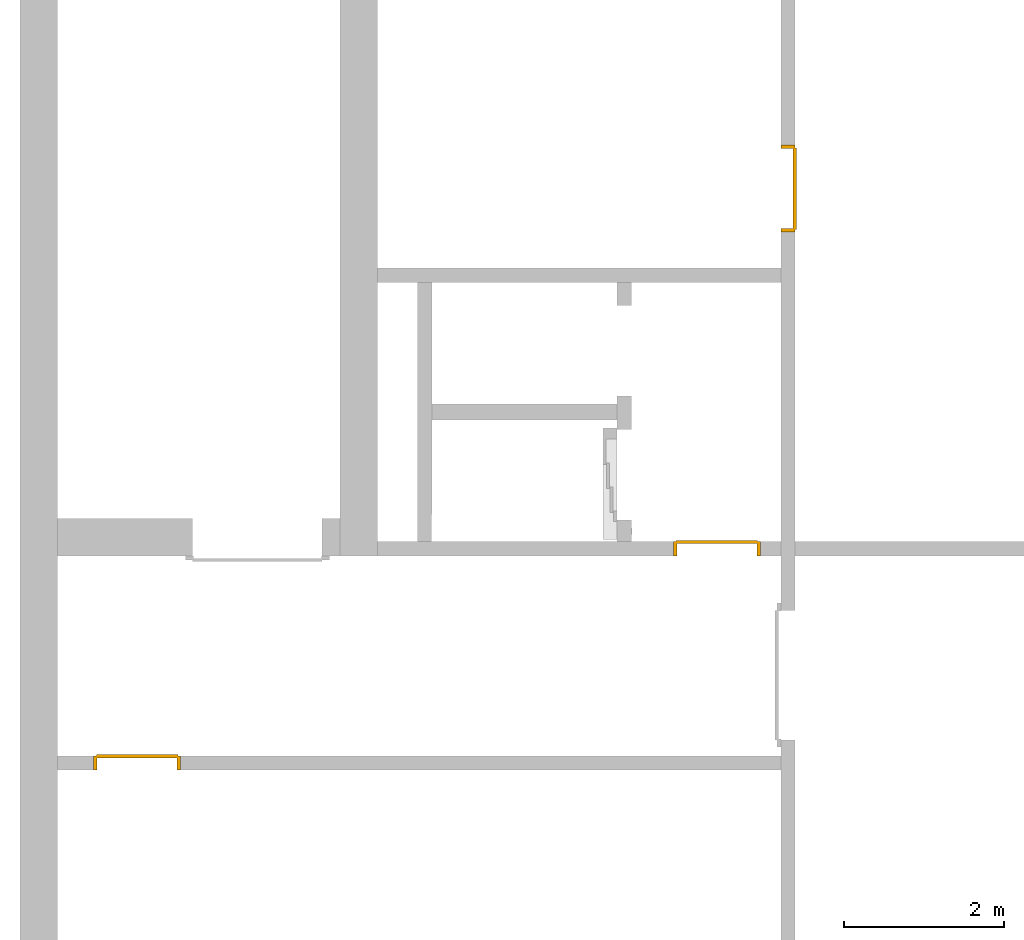
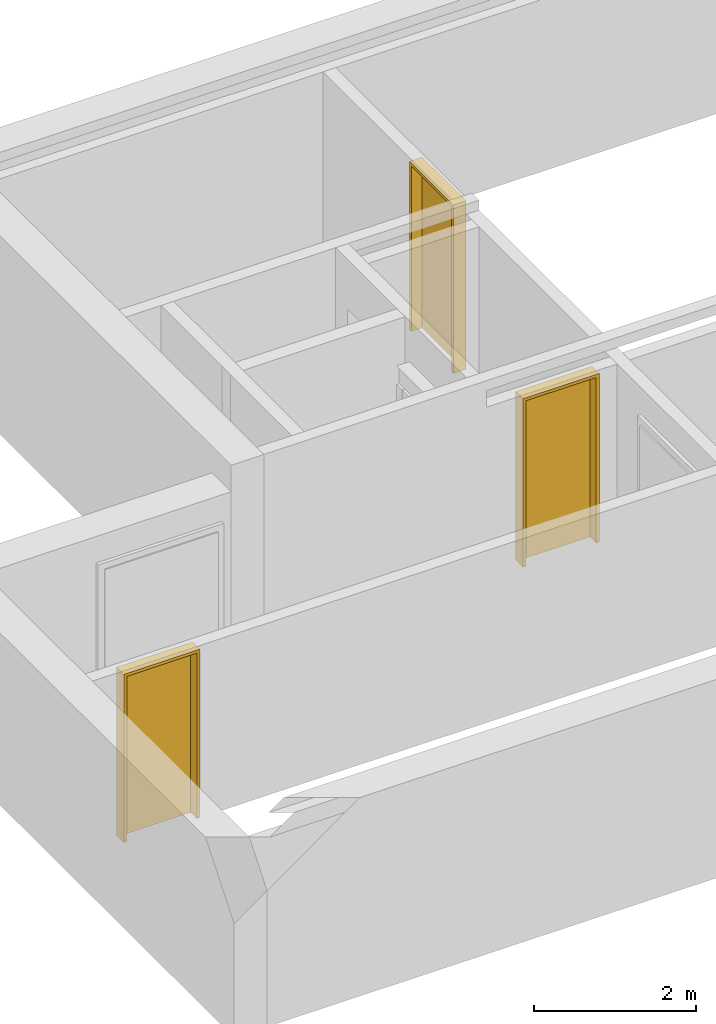
# One storey, part 3 of 3: 3 doors.
"""IFC4 building model written with IfcOpenShell, lengths in metres."""

from ifc_helpers import new_model, entity, si_unit, converted_unit, derived_unit, direction, frame, origin_with_axes, place, context, subcontext, project, spatial, polygons, type_object, element, save


model = new_model("IFC4")

# Units and contexts
model_context = context("Model", 3, precision=1e-05, world=origin_with_axes(), true_north=direction((0.0, 1.0)))
body_context = subcontext(model_context, "Body", "Model", "MODEL_VIEW")
ifc_project = project(units=[si_unit("LENGTHUNIT", "METRE"), si_unit("AREAUNIT", "SQUARE_METRE"), si_unit("VOLUMEUNIT", "CUBIC_METRE"), converted_unit("PLANEANGLEUNIT", "DEGREE", entity("IfcPlaneAngleMeasure", 0.0174532925199433), si_unit("PLANEANGLEUNIT", "RADIAN"), dimensions=[0, 0, 0, 0, 0, 0, 0]), converted_unit("TIMEUNIT", "Year", entity("IfcTimeMeasure", 31557600.0), si_unit("TIMEUNIT", "SECOND"), dimensions=[0, 0, 1, 0, 0, 0, 0]), si_unit("MASSUNIT", "GRAM", prefix="KILO"), si_unit("THERMODYNAMICTEMPERATUREUNIT", "DEGREE_CELSIUS"), si_unit("LUMINOUSINTENSITYUNIT", "LUMEN"), si_unit("ENERGYUNIT", "JOULE", prefix="MEGA"), derived_unit("THERMALCONDUCTANCEUNIT", [(si_unit("POWERUNIT", "WATT"), 1), (si_unit("LENGTHUNIT", "METRE"), -1), (si_unit("THERMODYNAMICTEMPERATUREUNIT", "KELVIN"), -1)]), derived_unit("SPECIFICHEATCAPACITYUNIT", [(si_unit("ENERGYUNIT", "JOULE"), 1), (si_unit("MASSUNIT", "GRAM", prefix="KILO"), -1), (si_unit("THERMODYNAMICTEMPERATUREUNIT", "KELVIN"), -1)]), derived_unit("MASSDENSITYUNIT", [(si_unit("MASSUNIT", "GRAM", prefix="KILO"), 1), (si_unit("VOLUMEUNIT", "CUBIC_METRE"), -1)])], contexts=[model_context])

# Site, building, storey
site_placement = place(None, origin_with_axes())
site = spatial("IfcSite", under=ifc_project, at=site_placement, CompositionType="ELEMENT")
building_placement = place(None, origin_with_axes())
building = spatial("IfcBuilding", under=site, at=building_placement, CompositionType="ELEMENT")
storey_placement = place(None, frame((0.0, 0.0, -3.0), z_axis=(0.0, 0.0, 1.0), x_axis=(1.0, 0.0, 0.0)))
storey = spatial("IfcBuildingStorey", under=building, at=storey_placement, Name="UG", CompositionType="ELEMENT", Elevation=-3.0)

# Doors
door_type_1 = type_object("IfcDoorType", Name="27", OperationType="SINGLE_SWING_LEFT", PredefinedType="DOOR")
door_1_placement = place(None, frame((33.505, 12.1499999454676, -3.0), z_axis=(0.0, 0.0, 1.0), x_axis=(0.0, -1.0, 0.0)))
element("IfcDoor", 1, at=door_1_placement, inside=storey, type_object=door_type_1, OverallHeight=2.545, OverallWidth=1.09, context=body_context, shape_type="Tessellation", body=[
    polygons([(-0.0449999999999999, 0.0, 0.0), (-0.0449999999999999, 0.0, 2.545), (-0.0449999999999999, 0.155000000000001, 2.545), (-0.0449999999999999, 0.155000000000001, 0.0), (0.0, 0.0, 0.0), (0.0, 0.0, 2.5), (0.444900000000001, 0.0, 2.5), (0.4999, 0.0, 2.5), (1.0, 0.0, 2.5), (1.0, 0.0, 0.0), (1.045, 0.0, 0.0), (1.045, 0.0, 2.545), (1.045, 0.155000000000001, 2.545), (1.045, 0.155000000000001, 0.0), (1.0, 0.155000000000001, 0.0), (1.0, 0.155000000000001, 2.5), (0.4999, 0.155000000000001, 2.5), (0.444900000000001, 0.155000000000001, 2.5), (0.0, 0.155000000000001, 2.5), (0.0, 0.155000000000001, 0.0)], [[[1, 2, 3, 4]], [[1, 5, 6, 7, 8, 9, 10, 11, 12, 2]], [[2, 12, 13, 3]], [[4, 3, 13, 14, 15, 16, 17, 18, 19, 20]], [[5, 1, 4, 20]], [[6, 5, 20, 19]], [[7, 6, 19, 18]], [[8, 7, 18, 17]], [[9, 8, 17, 16]], [[10, 9, 16, 15]], [[11, 10, 15, 14]], [[12, 11, 14, 13]]], closed=True),
    polygons([(-0.0449999999999999, 0.155000000000001, 0.0), (-0.0449999999999999, 0.155000000000001, 2.545), (-0.0449999999999999, 0.18, 2.545), (-0.0449999999999999, 0.18, 0.0), (-0.00999999999999979, 0.155000000000001, 0.0), (-0.00999999999999979, 0.155000000000001, 2.51), (0.4549, 0.155000000000001, 2.51), (0.4899, 0.155000000000001, 2.51), (1.01, 0.155000000000001, 2.51), (1.01, 0.155000000000001, 0.0), (1.045, 0.155000000000001, 0.0), (1.045, 0.155000000000001, 2.545), (1.045, 0.18, 2.545), (1.045, 0.18, 0.0), (1.01, 0.18, 0.0), (1.01, 0.18, 2.51), (0.4899, 0.18, 2.51), (0.4549, 0.18, 2.51), (-0.00999999999999979, 0.18, 2.51), (-0.00999999999999979, 0.18, 0.0)], [[[1, 2, 3, 4]], [[1, 5, 6, 7, 8, 9, 10, 11, 12, 2]], [[2, 12, 13, 3]], [[4, 3, 13, 14, 15, 16, 17, 18, 19, 20]], [[5, 1, 4, 20]], [[6, 5, 20, 19]], [[7, 6, 19, 18]], [[8, 7, 18, 17]], [[9, 8, 17, 16]], [[10, 9, 16, 15]], [[11, 10, 15, 14]], [[12, 11, 14, 13]]], closed=True),
    polygons([(-0.00999999999999979, 0.195, 0.0), (-0.00999999999999979, 0.195, 2.51), (1.01, 0.195, 2.51), (1.01, 0.195, 0.0), (-0.00999999999999979, 0.155000000000001, 0.0), (-0.00999999999999979, 0.155000000000001, 2.51), (1.01, 0.155000000000001, 2.51), (1.01, 0.155000000000001, 0.0)], [[[1, 2, 3, 4]], [[1, 5, 6, 2]], [[2, 6, 7, 3]], [[3, 7, 8, 4]], [[4, 8, 5, 1]], [[8, 7, 6, 5]]], closed=True),
])
door_2_placement = place(None, frame((24.953, 4.55499994546755, -3.0), z_axis=(0.0, 0.0, 1.0), x_axis=(1.0, 0.0, 0.0)))
element("IfcDoor", 2, at=door_2_placement, inside=storey, type_object=door_type_1, OverallHeight=2.545, OverallWidth=1.09, context=body_context, shape_type="Tessellation", body=[
    polygons([(-0.0449999999999982, -0.179999999999999, 0.0), (-0.0449999999999982, -0.179999999999999, 2.545), (-0.0449999999999982, -0.0249999999999995, 2.545), (-0.0449999999999982, -0.0249999999999986, 0.0), (0.0, -0.179999999999999, 0.0), (0.0, -0.179999999999999, 2.5), (0.444900000000001, -0.179999999999999, 2.5), (0.4999, -0.179999999999999, 2.5), (1.0, -0.18, 2.5), (1.0, -0.179999999999999, 0.0), (1.045, -0.179999999999999, 0.0), (1.045, -0.18, 2.545), (1.045, -0.0249999999999995, 2.545), (1.045, -0.0249999999999995, 0.0), (1.0, -0.0249999999999995, 0.0), (1.0, -0.0249999999999995, 2.5), (0.4999, -0.0249999999999995, 2.5), (0.444900000000001, -0.0249999999999995, 2.5), (0.0, -0.0249999999999995, 2.5), (0.0, -0.0249999999999986, 0.0)], [[[1, 2, 3, 4]], [[1, 5, 6, 7, 8, 9, 10, 11, 12, 2]], [[2, 12, 13, 3]], [[4, 3, 13, 14, 15, 16, 17, 18, 19, 20]], [[5, 1, 4, 20]], [[6, 5, 20, 19]], [[7, 6, 19, 18]], [[8, 7, 18, 17]], [[9, 8, 17, 16]], [[10, 9, 16, 15]], [[11, 10, 15, 14]], [[12, 11, 14, 13]]], closed=True),
    polygons([(-0.0449999999999982, -0.0249999999999986, 0.0), (-0.0449999999999982, -0.0249999999999995, 2.545), (-0.0449999999999982, 0.0, 2.545), (-0.0449999999999982, 0.0, 0.0), (-0.0100000000000016, -0.0249999999999986, 0.0), (-0.0100000000000016, -0.0249999999999995, 2.51), (0.454899999999999, -0.0249999999999995, 2.51), (0.489899999999999, -0.0249999999999995, 2.51), (1.01, -0.0249999999999995, 2.51), (1.01, -0.0249999999999995, 0.0), (1.045, -0.0249999999999995, 0.0), (1.045, -0.0249999999999995, 2.545), (1.045, 0.0, 2.545), (1.045, 0.0, 0.0), (1.01, 0.0, 0.0), (1.01, 0.0, 2.51), (0.489899999999999, 0.0, 2.51), (0.454899999999999, 0.0, 2.51), (-0.0100000000000016, 0.0, 2.51), (-0.0100000000000016, 0.0, 0.0)], [[[1, 2, 3, 4]], [[1, 5, 6, 7, 8, 9, 10, 11, 12, 2]], [[2, 12, 13, 3]], [[4, 3, 13, 14, 15, 16, 17, 18, 19, 20]], [[5, 1, 4, 20]], [[6, 5, 20, 19]], [[7, 6, 19, 18]], [[8, 7, 18, 17]], [[9, 8, 17, 16]], [[10, 9, 16, 15]], [[11, 10, 15, 14]], [[12, 11, 14, 13]]], closed=True),
    polygons([(-0.0100000000000016, 0.0150000000000015, 0.0), (-0.0100000000000016, 0.0150000000000006, 2.51), (1.01, 0.0150000000000006, 2.51), (1.01, 0.0150000000000006, 0.0), (-0.0100000000000016, -0.0249999999999986, 0.0), (-0.0100000000000016, -0.0249999999999995, 2.51), (1.01, -0.0249999999999995, 2.51), (1.01, -0.0249999999999995, 0.0)], [[[1, 2, 3, 4]], [[1, 5, 6, 2]], [[2, 6, 7, 3]], [[3, 7, 8, 4]], [[4, 8, 5, 1]], [[8, 7, 6, 5]]], closed=True),
])
door_type_2 = type_object("IfcDoorType", Name="27", OperationType="SINGLE_SWING_RIGHT", PredefinedType="DOOR")
door_3_placement = place(None, frame((32.205, 7.05499994546755, -3.0), z_axis=(0.0, 0.0, 1.0), x_axis=(1.0, 0.0, 0.0)))
element("IfcDoor", 3, at=door_3_placement, inside=storey, type_object=door_type_2, OverallHeight=2.545, OverallWidth=1.09, context=body_context, shape_type="Tessellation", body=[
    polygons([(1.045, 0.0, 0.0), (1.045, 0.154999999999999, 0.0), (1.045, 0.155, 2.545), (1.045, 0.0, 2.545), (1.0, 0.0, 0.0), (1.0, 0.154999999999999, 0.0), (1.0, 0.155, 2.5), (0.555100000000003, 0.155, 2.5), (0.500100000000003, 0.155, 2.5), (0.0, 0.155, 2.5), (0.0, 0.154999999999999, 0.0), (-0.0450000000000017, 0.154999999999999, 0.0), (-0.0450000000000017, 0.155, 2.545), (-0.0450000000000017, 0.0, 2.545), (-0.0450000000000017, 0.0, 0.0), (0.0, 0.0, 0.0), (0.0, 0.0, 2.5), (0.500100000000003, 0.0, 2.5), (0.555100000000003, 0.0, 2.5), (1.0, 0.0, 2.5)], [[[1, 2, 3, 4]], [[5, 6, 2, 1]], [[2, 6, 7, 8, 9, 10, 11, 12, 13, 3]], [[4, 3, 13, 14]], [[1, 4, 14, 15, 16, 17, 18, 19, 20, 5]], [[20, 7, 6, 5]], [[19, 8, 7, 20]], [[18, 9, 8, 19]], [[17, 10, 9, 18]], [[16, 11, 10, 17]], [[15, 12, 11, 16]], [[14, 13, 12, 15]]], closed=True),
    polygons([(1.045, 0.154999999999999, 0.0), (1.045, 0.18, 0.0), (1.045, 0.18, 2.545), (1.045, 0.155, 2.545), (1.01, 0.154999999999999, 0.0), (1.01, 0.18, 0.0), (1.01, 0.18, 2.51), (0.545099999999998, 0.18, 2.51), (0.510100000000001, 0.18, 2.51), (-0.00999999999999801, 0.18, 2.51), (-0.00999999999999801, 0.18, 0.0), (-0.0450000000000017, 0.18, 0.0), (-0.0450000000000017, 0.18, 2.545), (-0.0450000000000017, 0.155, 2.545), (-0.0450000000000017, 0.154999999999999, 0.0), (-0.00999999999999801, 0.154999999999999, 0.0), (-0.00999999999999801, 0.155, 2.51), (0.510100000000001, 0.155, 2.51), (0.545099999999998, 0.155, 2.51), (1.01, 0.155, 2.51)], [[[1, 2, 3, 4]], [[5, 6, 2, 1]], [[2, 6, 7, 8, 9, 10, 11, 12, 13, 3]], [[4, 3, 13, 14]], [[1, 4, 14, 15, 16, 17, 18, 19, 20, 5]], [[20, 7, 6, 5]], [[19, 8, 7, 20]], [[18, 9, 8, 19]], [[17, 10, 9, 18]], [[16, 11, 10, 17]], [[15, 12, 11, 16]], [[14, 13, 12, 15]]], closed=True),
    polygons([(1.01, 0.194999999999999, 0.0), (-0.00999999999999801, 0.194999999999999, 0.0), (-0.00999999999999801, 0.195, 2.51), (1.01, 0.195, 2.51), (1.01, 0.154999999999999, 0.0), (-0.00999999999999801, 0.154999999999999, 0.0), (-0.00999999999999801, 0.155, 2.51), (1.01, 0.155, 2.51)], [[[1, 2, 3, 4]], [[2, 1, 5, 6]], [[3, 2, 6, 7]], [[4, 3, 7, 8]], [[1, 4, 8, 5]], [[6, 5, 8, 7]]], closed=True),
])

save(model, "model.ifc")
